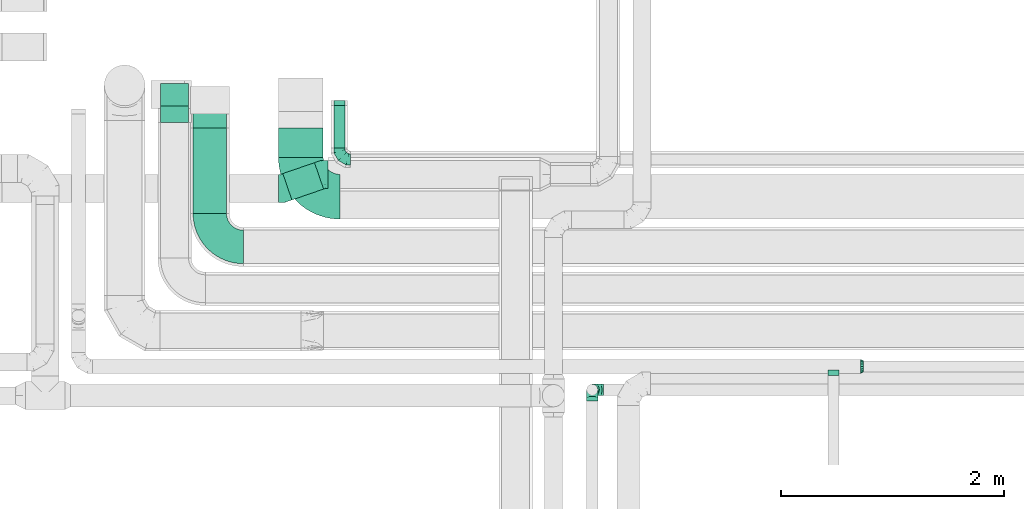
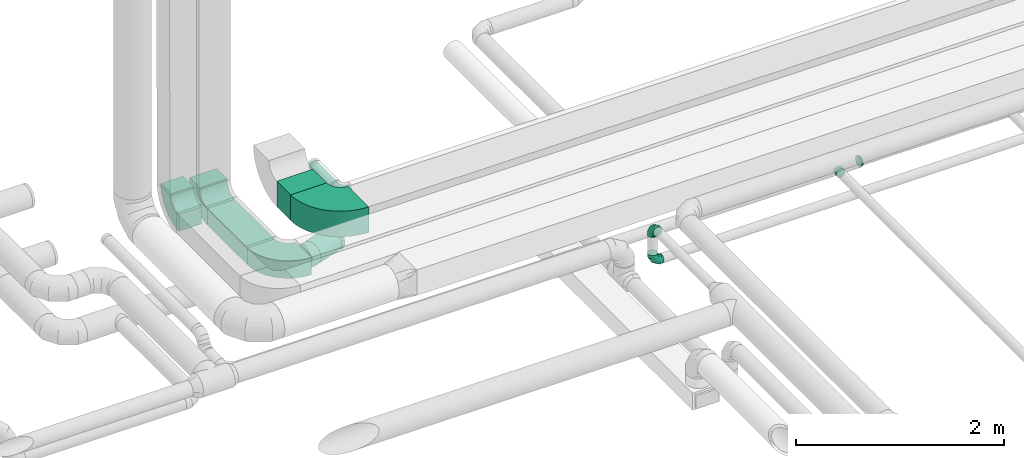
# One storey, part 39 of 92: 12 flow fittings, 4 flow segments.
"""IFC2X3 building model written with IfcOpenShell, lengths in millimetres."""

from ifc_helpers import new_model, entity, si_unit, converted_unit, derived_unit, direction, frame, frame_2d, origin, origin_2d_with_axis, place, context, subcontext, project, spatial, polyline, circle_curve, parameter, trimmed, segment, composite_curve, rectangle, circle, outline, extrude, faceted_brep, source, transform, mapped, material, type_object, type_shapes, element, save


model = new_model("IFC2X3")

# Units and contexts
model_context = context("Model", 3, precision=0.01, world=origin(), true_north=direction((6.12303176911189e-17, 1.0)))
body_context = subcontext(model_context, "Body", "Model", "MODEL_VIEW")
ifc_project = project(units=[si_unit("LENGTHUNIT", "METRE", prefix="MILLI"), si_unit("AREAUNIT", "SQUARE_METRE"), si_unit("VOLUMEUNIT", "CUBIC_METRE"), converted_unit("PLANEANGLEUNIT", "DEGREE", entity("IfcRatioMeasure", 0.0174532925199433), si_unit("PLANEANGLEUNIT", "RADIAN"), dimensions=[0, 0, 0, 0, 0, 0, 0]), si_unit("MASSUNIT", "GRAM", prefix="KILO"), derived_unit("MASSDENSITYUNIT", [(si_unit("MASSUNIT", "GRAM", prefix="KILO"), 1), (si_unit("LENGTHUNIT", "METRE"), -3)]), derived_unit("MOMENTOFINERTIAUNIT", [(si_unit("LENGTHUNIT", "METRE"), 4)]), si_unit("TIMEUNIT", "SECOND"), si_unit("FREQUENCYUNIT", "HERTZ"), si_unit("THERMODYNAMICTEMPERATUREUNIT", "DEGREE_CELSIUS"), derived_unit("THERMALTRANSMITTANCEUNIT", [(si_unit("MASSUNIT", "GRAM", prefix="KILO"), 1), (si_unit("THERMODYNAMICTEMPERATUREUNIT", "KELVIN"), -1), (si_unit("TIMEUNIT", "SECOND"), -3)]), derived_unit("VOLUMETRICFLOWRATEUNIT", [(si_unit("LENGTHUNIT", "METRE"), 3), (si_unit("TIMEUNIT", "SECOND"), -1)]), derived_unit("MASSFLOWRATEUNIT", [(si_unit("MASSUNIT", "GRAM", prefix="KILO"), 1), (si_unit("TIMEUNIT", "SECOND"), -1)]), derived_unit("ROTATIONALFREQUENCYUNIT", [(si_unit("TIMEUNIT", "SECOND"), -1)]), si_unit("ELECTRICCURRENTUNIT", "AMPERE"), si_unit("ELECTRICVOLTAGEUNIT", "VOLT"), si_unit("POWERUNIT", "WATT"), si_unit("FORCEUNIT", "NEWTON", prefix="KILO"), si_unit("ILLUMINANCEUNIT", "LUX"), si_unit("LUMINOUSFLUXUNIT", "LUMEN"), si_unit("LUMINOUSINTENSITYUNIT", "CANDELA"), derived_unit("USERDEFINED", [(si_unit("MASSUNIT", "GRAM", prefix="KILO"), -1), (si_unit("LENGTHUNIT", "METRE"), -2), (si_unit("TIMEUNIT", "SECOND"), 3), (si_unit("LUMINOUSFLUXUNIT", "LUMEN"), 1)]), derived_unit("LINEARVELOCITYUNIT", [(si_unit("LENGTHUNIT", "METRE"), 1), (si_unit("TIMEUNIT", "SECOND"), -1)]), si_unit("PRESSUREUNIT", "PASCAL"), derived_unit("USERDEFINED", [(si_unit("LENGTHUNIT", "METRE"), -2), (si_unit("MASSUNIT", "GRAM", prefix="KILO"), 1), (si_unit("TIMEUNIT", "SECOND"), -2)]), derived_unit("LINEARFORCEUNIT", [(si_unit("MASSUNIT", "GRAM", prefix="KILO"), 1), (si_unit("LENGTHUNIT", "METRE"), 1), (si_unit("TIMEUNIT", "SECOND"), -2), (si_unit("LENGTHUNIT", "METRE"), -1)]), derived_unit("PLANARFORCEUNIT", [(si_unit("MASSUNIT", "GRAM", prefix="KILO"), 1), (si_unit("LENGTHUNIT", "METRE"), 1), (si_unit("TIMEUNIT", "SECOND"), -2), (si_unit("LENGTHUNIT", "METRE"), -2)])], contexts=[model_context])

# Site, building, storey
site_placement = place(None, origin())
site = spatial("IfcSite", under=ifc_project, at=site_placement, CompositionType="ELEMENT")
building_placement = place(site_placement, origin())
building = spatial("IfcBuilding", under=site, at=building_placement, CompositionType="ELEMENT")
storey_placement = place(building_placement, frame((0.0, 0.0, 4200.0)))
storey = spatial("IfcBuildingStorey", under=building, at=storey_placement, CompositionType="ELEMENT", Elevation=4200.0)

# Flow segments
duct_segment_type_1 = type_object("IfcDuctSegmentType", PredefinedType="NOTDEFINED")
flow_segment_1_placement = place(storey_placement, frame((9980.0, 13369.63, 3150.0)))
element("IfcFlowSegment", 1, at=flow_segment_1_placement, inside=storey, type_object=duct_segment_type_1, context=body_context, shape_type="SweptSolid", body=[
    extrude(rectangle(XDim=264.384478781449, YDim=400.0, at=origin_2d_with_axis()), frame((200.0, 132.19, 0.0), z_axis=(0.0, 0.0, 1.0), x_axis=(0.0, -1.0, 0.0)), (0.0, 0.0, 1.0), 300.000000000001),
])
flow_segment_2_placement = place(storey_placement, frame((9214.47, 12869.66, 3200.0)))
element("IfcFlowSegment", 2, at=flow_segment_2_placement, inside=storey, type_object=duct_segment_type_1, context=body_context, shape_type="SweptSolid", body=[
    extrude(rectangle(XDim=764.374757491824, YDim=300.0, at=origin_2d_with_axis()), frame((150.0, 382.19, 0.0), z_axis=(0.0, 0.0, 1.0), x_axis=(0.0, 1.0, 0.0)), (0.0, 0.0, 1.0), 200.0),
])
duct_segment_type_2 = type_object("IfcDuctSegmentType", PredefinedType="NOTDEFINED")
flow_segment_3_placement = place(storey_placement, frame((10473.31, 13454.28, 3248.4)))
element("IfcFlowSegment", 3, at=flow_segment_3_placement, inside=storey, type_object=duct_segment_type_2, context=body_context, shape_type="SweptSolid", body=[
    extrude(circle(Radius=50.0, at=origin_2d_with_axis()), frame((51.6, 0.0, 51.6), z_axis=(0.0, 1.0, 0.0), x_axis=(1.0, 0.0, 0.0)), (0.0, 0.0, 1.0), 382.222629872905),
])
flow_segment_4_placement = place(storey_placement, frame((10016.94, 12988.87, 2773.4)))
element("IfcFlowSegment", 4, at=flow_segment_4_placement, inside=storey, type_object=duct_segment_type_2, context=body_context, shape_type="SweptSolid", body=[
    extrude(circle(Radius=125.0, at=origin_2d_with_axis()), frame((42.29, 119.79, 126.6), z_axis=(0.945518575599296, 0.325568154457217, 0.0), x_axis=(-0.325568154457217, 0.945518575599296, 0.0)), (0.0, 0.0, 1.0), 300.171197948782),
])

# Flow fittings
ifc_material = material()
duct_fitting_type_1 = type_object("IfcDuctFittingType", PredefinedType="NOTDEFINED", material=ifc_material)
shared_shape_1 = source(origin(), body_context, "Body", "Brep", [
    faceted_brep([(-100.0, 0.0, -50.0), (-100.0, -12.94, -48.3), (-100.0, -25.0, -43.3), (-100.0, -35.36, -35.36), (-100.0, -43.3, -25.0), (-100.0, -48.3, -12.94), (-100.0, -50.0, 0.0), (-100.0, -48.3, 12.94), (-100.0, -43.3, 25.0), (-100.0, -35.36, 35.36), (-100.0, -25.0, 43.3), (-100.0, -12.94, 48.3), (-100.0, 0.0, 50.0), (-100.0, 12.94, 48.3), (-100.0, 25.0, 43.3), (-100.0, 35.36, 35.36), (-100.0, 43.3, 25.0), (-100.0, 48.3, 12.94), (-100.0, 50.0, 0.0), (-100.0, 48.3, -12.94), (-100.0, 43.3, -25.0), (-100.0, 35.36, -35.36), (-100.0, 25.0, -43.3), (-100.0, 12.94, -48.3), (-76.67, 12.94, 48.3), (-79.9, 25.0, 43.3), (-73.21, 0.0, 50.0), (-82.68, 35.36, 35.36), (-86.15, 48.3, 12.94), (-86.6, 50.0, 0.0), (-84.81, 43.3, 25.0), (-84.81, 43.3, -25.0), (-82.68, 35.36, -35.36), (-86.15, 48.3, -12.94), (-76.67, 12.94, -48.3), (-73.21, 0.0, -50.0), (-79.9, 25.0, -43.3), (-69.74, -12.94, -48.3), (-66.51, -25.0, -43.3), (-63.73, -35.36, -35.36), (-61.6, -43.3, -25.0), (-60.26, -48.3, -12.94), (-59.81, -50.0, 0.0), (-60.26, -48.3, 12.94), (-61.6, -43.3, 25.0), (-63.73, -35.36, 35.36), (-66.51, -25.0, 43.3), (-69.74, -12.94, 48.3), (-36.27, 36.27, 48.3), (-45.1, 45.1, 43.3), (-26.79, 26.79, 50.0), (-52.68, 52.68, 35.36), (-58.49, 58.49, 25.0), (-62.15, 62.15, 12.94), (-63.4, 63.4, 0.0), (-62.15, 62.15, -12.94), (-58.49, 58.49, -25.0), (-52.68, 52.68, -35.36), (-36.27, 36.27, -48.3), (-26.79, 26.79, -50.0), (-45.1, 45.1, -43.3), (-17.32, 17.32, -48.3), (-8.49, 8.49, -43.3), (-0.91, 0.91, -35.36), (4.9, -4.9, -25.0), (8.56, -8.56, -12.94), (9.81, -9.81, 0.0), (8.56, -8.56, 12.94), (4.9, -4.9, 25.0), (-0.91, 0.91, 35.36), (-8.49, 8.49, 43.3), (-17.32, 17.32, 48.3), (-12.94, 76.67, 48.3), (-25.0, 79.9, 43.3), (0.0, 73.21, 50.0), (-35.36, 82.68, 35.36), (-43.3, 84.81, 25.0), (-48.3, 86.15, 12.94), (-50.0, 86.6, 0.0), (-48.3, 86.15, -12.94), (-43.3, 84.81, -25.0), (-35.36, 82.68, -35.36), (-12.94, 76.67, -48.3), (0.0, 73.21, -50.0), (-25.0, 79.9, -43.3), (12.94, 69.74, -48.3), (25.0, 66.51, -43.3), (35.36, 63.73, -35.36), (43.3, 61.6, -25.0), (48.3, 60.26, -12.94), (50.0, 59.81, 0.0), (48.3, 60.26, 12.94), (43.3, 61.6, 25.0), (35.36, 63.73, 35.36), (25.0, 66.51, 43.3), (12.94, 69.74, 48.3), (-12.94, 100.0, -48.3), (-25.0, 100.0, -43.3), (-35.36, 100.0, -35.36), (-43.3, 100.0, -25.0), (-48.3, 100.0, -12.94), (-50.0, 100.0, 0.0), (-48.3, 100.0, 12.94), (-43.3, 100.0, 25.0), (-35.36, 100.0, 35.36), (-25.0, 100.0, 43.3), (-12.94, 100.0, 48.3), (0.0, 100.0, 50.0), (12.94, 100.0, 48.3), (25.0, 100.0, 43.3), (35.36, 100.0, 35.36), (43.3, 100.0, 25.0), (48.3, 100.0, 12.94), (50.0, 100.0, 0.0), (48.3, 100.0, -12.94), (43.3, 100.0, -25.0), (35.36, 100.0, -35.36), (25.0, 100.0, -43.3), (12.94, 100.0, -48.3), (0.0, 100.0, -50.0)], [[[0, 1, 2, 3, 4, 5, 6, 7, 8, 9, 10, 11, 12, 13, 14, 15, 16, 17, 18, 19, 20, 21, 22, 23]], [[24, 25, 14, 13]], [[26, 24, 13, 12]], [[14, 25, 27, 15]], [[28, 29, 18, 17]], [[30, 28, 17, 16]], [[15, 27, 30, 16]], [[20, 31, 32, 21]], [[33, 31, 20, 19]], [[18, 29, 33, 19]], [[34, 35, 0, 23]], [[36, 34, 23, 22]], [[32, 36, 22, 21]], [[2, 1, 37, 38]], [[3, 2, 38, 39]], [[0, 35, 37, 1]], [[5, 4, 40, 41]], [[6, 5, 41, 42]], [[3, 39, 40, 4]], [[6, 42, 43, 7]], [[7, 43, 44, 8]], [[8, 44, 45, 9]], [[10, 46, 47, 11]], [[11, 47, 26, 12]], [[10, 9, 45, 46]], [[48, 49, 25, 24]], [[50, 48, 24, 26]], [[27, 25, 49, 51]], [[52, 53, 28, 30]], [[51, 52, 30, 27]], [[29, 28, 53, 54]], [[55, 56, 31, 33]], [[54, 55, 33, 29]], [[57, 32, 31, 56]], [[58, 59, 35, 34]], [[60, 58, 34, 36]], [[57, 60, 36, 32]], [[37, 35, 59, 61]], [[38, 37, 61, 62]], [[39, 38, 62, 63]], [[41, 40, 64, 65]], [[42, 41, 65, 66]], [[63, 64, 40, 39]], [[43, 42, 66, 67]], [[44, 43, 67, 68]], [[68, 69, 45, 44]], [[46, 45, 69, 70]], [[47, 46, 70, 71]], [[26, 47, 71, 50]], [[72, 73, 49, 48]], [[74, 72, 48, 50]], [[51, 49, 73, 75]], [[76, 77, 53, 52]], [[75, 76, 52, 51]], [[54, 53, 77, 78]], [[79, 80, 56, 55]], [[78, 79, 55, 54]], [[81, 57, 56, 80]], [[82, 83, 59, 58]], [[84, 82, 58, 60]], [[81, 84, 60, 57]], [[61, 59, 83, 85]], [[62, 61, 85, 86]], [[63, 62, 86, 87]], [[65, 64, 88, 89]], [[66, 65, 89, 90]], [[87, 88, 64, 63]], [[67, 66, 90, 91]], [[68, 67, 91, 92]], [[92, 93, 69, 68]], [[70, 69, 93, 94]], [[71, 70, 94, 95]], [[50, 71, 95, 74]], [[96, 97, 98, 99, 100, 101, 102, 103, 104, 105, 106, 107, 108, 109, 110, 111, 112, 113, 114, 115, 116, 117, 118, 119]], [[72, 74, 107, 106]], [[73, 72, 106, 105]], [[75, 73, 105, 104]], [[77, 76, 103, 102]], [[78, 77, 102, 101]], [[75, 104, 103, 76]], [[78, 101, 100, 79]], [[79, 100, 99, 80]], [[80, 99, 98, 81]], [[96, 119, 83, 82]], [[97, 96, 82, 84]], [[84, 81, 98, 97]], [[83, 119, 118, 85]], [[85, 118, 117, 86]], [[86, 117, 116, 87]], [[88, 115, 114, 89]], [[89, 114, 113, 90]], [[87, 116, 115, 88]], [[91, 90, 113, 112]], [[92, 91, 112, 111]], [[93, 92, 111, 110]], [[95, 94, 109, 108]], [[74, 95, 108, 107]], [[110, 109, 94, 93]]]),
])
type_shapes(duct_fitting_type_1, [shared_shape_1])
for number, where, z_axis, x_axis in (
    (5, (10524.9, 13354.28, 3300.0), (0.0, 0.0, 1.0), (0.0, -1.0, 0.0)),
    (6, (12790.5, 11289.94, 2950.0), (0.0, 1.0, 0.0), (-1.0, 0.0, 0.0)),
    (7, (12790.5, 11289.94, 3360.0), (1.0, 0.0, 0.0), (0.0, 0.0, 1.0)),
):
    element("IfcFlowFitting", number, at=place(storey_placement, frame(where, z_axis=z_axis, x_axis=x_axis)), inside=storey, type_object=duct_fitting_type_1, material=ifc_material, context=body_context, shape_type="MappedRepresentation", body=[
        mapped(shared_shape_1, transform((0.0, 0.0, 0.0), scale=1.0)),
    ])
duct_fitting_type_2 = type_object("IfcDuctFittingType", PredefinedType="NOTDEFINED", material=ifc_material)
shared_shape_2 = source(origin(), body_context, "Body", "Brep", [
    faceted_brep([(20.0, 12.94, -48.3), (20.0, 25.0, -43.3), (20.0, 35.36, -35.36), (20.0, 43.3, -25.0), (20.0, 48.3, -12.94), (20.0, 50.0, 0.0), (20.0, 48.3, 12.94), (20.0, 43.3, 25.0), (20.0, 35.36, 35.36), (20.0, 25.0, 43.3), (20.0, 12.94, 48.3), (20.0, 0.0, 50.0), (20.0, -12.94, 48.3), (20.0, -25.0, 43.3), (20.0, -35.36, 35.36), (20.0, -43.3, 25.0), (20.0, -48.3, 12.94), (20.0, -50.0, 0.0), (20.0, -48.3, -12.94), (20.0, -43.3, -25.0), (20.0, -35.36, -35.36), (20.0, -25.0, -43.3), (20.0, -12.94, -48.3), (20.0, 0.0, -50.0), (0.0, 0.0, 50.0), (0.0, 12.94, 48.3), (-23.65, 12.94, 48.3), (-23.65, 0.0, 50.0), (0.0, 25.0, 43.3), (-23.65, 25.0, 43.3), (0.0, 35.36, 35.36), (-23.65, 35.36, 35.36), (0.0, 43.3, 25.0), (0.0, 48.3, 12.94), (-23.65, 48.3, 12.94), (-23.65, 43.3, 25.0), (0.0, 50.0, 0.0), (-23.65, 50.0, 0.0), (0.0, 48.3, -12.94), (-23.65, 48.3, -12.94), (0.0, 43.3, -25.0), (-23.65, 43.3, -25.0), (0.0, 35.36, -35.36), (-23.65, 35.36, -35.36), (0.0, 25.0, -43.3), (0.0, 12.94, -48.3), (-23.65, 12.94, -48.3), (-23.65, 25.0, -43.3), (0.0, 0.0, -50.0), (-23.65, 0.0, -50.0), (0.0, -12.94, -48.3), (-23.65, -12.94, -48.3), (0.0, -25.0, -43.3), (-23.65, -25.0, -43.3), (0.0, -35.36, -35.36), (-23.65, -35.36, -35.36), (0.0, -43.3, -25.0), (0.0, -48.3, -12.94), (-23.65, -48.3, -12.94), (-23.65, -43.3, -25.0), (0.0, -50.0, 0.0), (-23.65, -50.0, 0.0), (0.0, -48.3, 12.94), (-23.65, -48.3, 12.94), (0.0, -43.3, 25.0), (-23.65, -43.3, 25.0), (0.0, -35.36, 35.36), (-23.65, -35.36, 35.36), (0.0, -25.0, 43.3), (0.0, -12.94, 48.3), (-23.65, -12.94, 48.3), (-23.65, -25.0, 43.3)], [[[0, 1, 2, 3, 4, 5, 6, 7, 8, 9, 10, 11, 12, 13, 14, 15, 16, 17, 18, 19, 20, 21, 22, 23]], [[24, 11, 10, 25, 26, 27]], [[25, 10, 9, 28, 29, 26]], [[28, 9, 8, 30, 31, 29]], [[32, 7, 6, 33, 34, 35]], [[33, 6, 5, 36, 37, 34]], [[30, 8, 7, 32, 35, 31]], [[36, 5, 4, 38, 39, 37]], [[38, 4, 3, 40, 41, 39]], [[40, 3, 2, 42, 43, 41]], [[44, 1, 0, 45, 46, 47]], [[45, 0, 23, 48, 49, 46]], [[42, 2, 1, 44, 47, 43]], [[48, 23, 22, 50, 51, 49]], [[50, 22, 21, 52, 53, 51]], [[52, 21, 20, 54, 55, 53]], [[56, 19, 18, 57, 58, 59]], [[57, 18, 17, 60, 61, 58]], [[54, 20, 19, 56, 59, 55]], [[60, 17, 16, 62, 63, 61]], [[62, 16, 15, 64, 65, 63]], [[64, 15, 14, 66, 67, 65]], [[68, 13, 12, 69, 70, 71]], [[69, 12, 11, 24, 27, 70]], [[66, 14, 13, 68, 71, 67]], [[49, 51, 53, 55, 59, 58, 61, 63, 65, 67, 71, 70, 27, 26, 29, 31, 35, 34, 37, 39, 41, 43, 47, 46]]]),
])
type_shapes(duct_fitting_type_2, [shared_shape_2])
flow_fitting_1_placement = place(storey_placement, frame((10524.9, 13856.5, 3300.0), z_axis=(-1.0, 0.0, 0.0), x_axis=(0.0, -1.0, 0.0)))
element("IfcFlowFitting", 8, at=flow_fitting_1_placement, inside=storey, type_object=duct_fitting_type_2, material=ifc_material, context=body_context, shape_type="MappedRepresentation", body=[
    mapped(shared_shape_2, transform((0.0, 0.0, 0.0), scale=1.0)),
])
duct_fitting_type_3 = type_object("IfcDuctFittingType", PredefinedType="NOTDEFINED", material=ifc_material)
shared_shape_3 = source(origin(), body_context, "Body", "Brep", [
    faceted_brep([(20.0, 12.94, -48.3), (20.0, 25.0, -43.3), (20.0, 35.36, -35.36), (20.0, 43.3, -25.0), (20.0, 48.3, -12.94), (20.0, 50.0, 0.0), (20.0, 48.3, 12.94), (20.0, 43.3, 25.0), (20.0, 35.36, 35.36), (20.0, 25.0, 43.3), (20.0, 12.94, 48.3), (20.0, 0.0, 50.0), (20.0, -12.94, 48.3), (20.0, -25.0, 43.3), (20.0, -35.36, 35.36), (20.0, -43.3, 25.0), (20.0, -48.3, 12.94), (20.0, -50.0, 0.0), (20.0, -48.3, -12.94), (20.0, -43.3, -25.0), (20.0, -35.36, -35.36), (20.0, -25.0, -43.3), (20.0, -12.94, -48.3), (20.0, 0.0, -50.0), (0.0, 0.0, 50.0), (0.0, 12.94, 48.3), (-31.1, 12.94, 48.3), (-31.1, 0.0, 50.0), (0.0, 25.0, 43.3), (-31.1, 25.0, 43.3), (0.0, 35.36, 35.36), (-31.1, 35.36, 35.36), (0.0, 43.3, 25.0), (0.0, 48.3, 12.94), (-31.1, 48.3, 12.94), (-31.1, 43.3, 25.0), (0.0, 50.0, 0.0), (-31.1, 50.0, 0.0), (0.0, 48.3, -12.94), (-31.1, 48.3, -12.94), (0.0, 43.3, -25.0), (-31.1, 43.3, -25.0), (0.0, 35.36, -35.36), (-31.1, 35.36, -35.36), (0.0, 25.0, -43.3), (0.0, 12.94, -48.3), (-31.1, 12.94, -48.3), (-31.1, 25.0, -43.3), (0.0, 0.0, -50.0), (-31.1, 0.0, -50.0), (0.0, -12.94, -48.3), (-31.1, -12.94, -48.3), (0.0, -25.0, -43.3), (-31.1, -25.0, -43.3), (0.0, -35.36, -35.36), (-31.1, -35.36, -35.36), (0.0, -43.3, -25.0), (0.0, -48.3, -12.94), (-31.1, -48.3, -12.94), (-31.1, -43.3, -25.0), (0.0, -50.0, 0.0), (-31.1, -50.0, 0.0), (0.0, -48.3, 12.94), (-31.1, -48.3, 12.94), (0.0, -43.3, 25.0), (-31.1, -43.3, 25.0), (0.0, -35.36, 35.36), (-31.1, -35.36, 35.36), (0.0, -25.0, 43.3), (0.0, -12.94, 48.3), (-31.1, -12.94, 48.3), (-31.1, -25.0, 43.3)], [[[0, 1, 2, 3, 4, 5, 6, 7, 8, 9, 10, 11, 12, 13, 14, 15, 16, 17, 18, 19, 20, 21, 22, 23]], [[24, 11, 10, 25, 26, 27]], [[25, 10, 9, 28, 29, 26]], [[28, 9, 8, 30, 31, 29]], [[32, 7, 6, 33, 34, 35]], [[33, 6, 5, 36, 37, 34]], [[30, 8, 7, 32, 35, 31]], [[36, 5, 4, 38, 39, 37]], [[38, 4, 3, 40, 41, 39]], [[40, 3, 2, 42, 43, 41]], [[44, 1, 0, 45, 46, 47]], [[45, 0, 23, 48, 49, 46]], [[42, 2, 1, 44, 47, 43]], [[48, 23, 22, 50, 51, 49]], [[50, 22, 21, 52, 53, 51]], [[52, 21, 20, 54, 55, 53]], [[56, 19, 18, 57, 58, 59]], [[57, 18, 17, 60, 61, 58]], [[54, 20, 19, 56, 59, 55]], [[60, 17, 16, 62, 63, 61]], [[62, 16, 15, 64, 65, 63]], [[64, 15, 14, 66, 67, 65]], [[68, 13, 12, 69, 70, 71]], [[69, 12, 11, 24, 27, 70]], [[66, 14, 13, 68, 71, 67]], [[49, 51, 53, 55, 59, 58, 61, 63, 65, 67, 71, 70, 27, 26, 29, 31, 35, 34, 37, 39, 41, 43, 47, 46]]]),
])
type_shapes(duct_fitting_type_3, [shared_shape_3])
flow_fitting_2_placement = place(storey_placement, frame((14950.42, 11437.18, 3150.0), z_axis=(0.0, 0.0, -1.0), x_axis=(0.0, -1.0, 0.0)))
element("IfcFlowFitting", 9, at=flow_fitting_2_placement, inside=storey, type_object=duct_fitting_type_3, material=ifc_material, context=body_context, shape_type="MappedRepresentation", body=[
    mapped(shared_shape_3, transform((0.0, 0.0, 0.0), scale=1.0)),
])
duct_fitting_type_4 = type_object("IfcDuctFittingType", PredefinedType="NOTDEFINED", material=ifc_material)
shared_shape_4 = source(origin(), body_context, "Body", "Brep", [
    faceted_brep([(25.0, 0.0, -62.5), (25.0, 12.45, -60.02), (25.0, 23.92, -57.74), (25.0, 34.06, -50.97), (25.0, 44.19, -44.19), (25.0, 50.97, -34.06), (25.0, 57.74, -23.92), (25.0, 60.02, -12.45), (25.0, 62.5, 0.0), (25.0, 60.02, 12.45), (25.0, 57.74, 23.92), (25.0, 50.97, 34.06), (25.0, 44.19, 44.19), (25.0, 34.06, 50.97), (25.0, 23.92, 57.74), (25.0, 12.45, 60.02), (25.0, 0.0, 62.5), (25.0, -12.45, 60.02), (25.0, -23.92, 57.74), (25.0, -34.06, 50.97), (25.0, -44.19, 44.19), (25.0, -50.97, 34.06), (25.0, -57.74, 23.92), (25.0, -60.02, 12.45), (25.0, -62.5, 0.0), (25.0, -60.02, -12.45), (25.0, -57.74, -23.92), (25.0, -50.97, -34.06), (25.0, -44.19, -44.19), (25.0, -34.06, -50.97), (25.0, -23.92, -57.74), (25.0, -12.45, -60.02), (0.0, -19.13, -46.19), (0.0, -27.24, -40.77), (0.0, -35.36, -35.36), (0.0, -40.77, -27.24), (0.0, -46.19, -19.13), (0.0, -48.1, -9.57), (0.0, -50.0, 0.0), (0.0, -48.1, 9.57), (0.0, -46.19, 19.13), (0.0, -40.77, 27.24), (0.0, -35.36, 35.36), (0.0, -27.24, 40.77), (0.0, -19.13, 46.19), (0.0, -9.57, 48.1), (0.0, 0.0, 50.0), (0.0, 9.57, 48.1), (0.0, 19.13, 46.19), (0.0, 27.24, 40.77), (0.0, 35.36, 35.36), (0.0, 40.77, 27.24), (0.0, 46.19, 19.13), (0.0, 48.1, 9.57), (0.0, 50.0, 0.0), (0.0, 48.1, -9.57), (0.0, 46.19, -19.13), (0.0, 40.77, -27.24), (0.0, 35.36, -35.36), (0.0, 27.24, -40.77), (0.0, 19.13, -46.19), (0.0, 9.57, -48.1), (0.0, 0.0, -50.0), (0.0, -9.57, -48.1)], [[[0, 1, 2, 3, 4, 5, 6, 7, 8, 9, 10, 11, 12, 13, 14, 15, 16, 17, 18, 19, 20, 21, 22, 23, 24, 25, 26, 27, 28, 29, 30, 31]], [[32, 33, 34, 35, 36, 37, 38, 39, 40, 41, 42, 43, 44, 45, 46, 47, 48, 49, 50, 51, 52, 53, 54, 55, 56, 57, 58, 59, 60, 61, 62, 63]], [[52, 10, 9, 8, 54, 53]], [[51, 50, 12, 11, 10, 52]], [[47, 46, 16, 15, 14, 48]], [[49, 48, 14, 13, 12, 50]], [[44, 18, 17, 16, 46, 45]], [[43, 42, 20, 19, 18, 44]], [[39, 38, 24, 23, 22, 40]], [[41, 40, 22, 21, 20, 42]], [[36, 26, 25, 24, 38, 37]], [[35, 34, 28, 27, 26, 36]], [[63, 62, 0, 31, 30, 32]], [[33, 32, 30, 29, 28, 34]], [[60, 2, 1, 0, 62, 61]], [[59, 58, 4, 3, 2, 60]], [[55, 54, 8, 7, 6, 56]], [[57, 56, 6, 5, 4, 58]]]),
])
type_shapes(duct_fitting_type_4, [shared_shape_4])
flow_fitting_3_placement = place(storey_placement, frame((15219.69, 11499.68, 3150.0), z_axis=(0.0, 0.0, 1.0), x_axis=(-1.0, 0.0, 0.0)))
element("IfcFlowFitting", 10, at=flow_fitting_3_placement, inside=storey, type_object=duct_fitting_type_4, material=ifc_material, context=body_context, shape_type="MappedRepresentation", body=[
    mapped(shared_shape_4, transform((0.0, 0.0, 0.0), scale=1.0)),
])
duct_fitting_type_5 = type_object("IfcDuctFittingType", PredefinedType="NOTDEFINED", material=ifc_material)
shared_shape_5 = source(origin(), body_context, "Body", "Brep", [
    faceted_brep([(-41.84, 0.0, -125.0), (-41.84, -32.35, -120.74), (-41.84, -62.5, -108.25), (-41.84, -88.39, -88.39), (-41.84, -108.25, -62.5), (-41.84, -120.74, -32.35), (-41.84, -125.0, 0.0), (-41.84, -120.74, 32.35), (-41.84, -108.25, 62.5), (-41.84, -88.39, 88.39), (-41.84, -62.5, 108.25), (-41.84, -32.35, 120.74), (-41.84, 0.0, 125.0), (-41.84, 32.35, 120.74), (-41.84, 62.5, 108.25), (-41.84, 88.39, 88.39), (-41.84, 108.25, 62.5), (-41.84, 120.74, 32.35), (-41.84, 125.0, 0.0), (-41.84, 120.74, -32.35), (-41.84, 108.25, -62.5), (-41.84, 88.39, -88.39), (-41.84, 62.5, -108.25), (-41.84, 32.35, -120.74), (-5.41, 32.35, 120.74), (-10.46, 62.5, 108.25), (0.0, 0.0, 125.0), (-14.79, 88.39, 88.39), (-20.21, 120.74, 32.35), (-20.92, 125.0, 0.0), (-18.12, 108.25, 62.5), (-18.12, 108.25, -62.5), (-14.79, 88.39, -88.39), (-20.21, 120.74, -32.35), (-5.41, 32.35, -120.74), (0.0, 0.0, -125.0), (-10.46, 62.5, -108.25), (5.41, -32.35, -120.74), (10.46, -62.5, -108.25), (14.79, -88.39, -88.39), (18.12, -108.25, -62.5), (20.21, -120.74, -32.35), (20.92, -125.0, 0.0), (20.21, -120.74, 32.35), (18.12, -108.25, 62.5), (14.79, -88.39, 88.39), (10.46, -62.5, 108.25), (5.41, -32.35, 120.74), (39.56, 13.62, 125.0), (29.02, 44.21, 120.74), (19.21, 72.72, 108.25), (10.78, 97.19, 88.39), (4.31, 115.98, 62.5), (0.25, 127.78, 32.35), (-1.14, 131.81, 0.0), (0.25, 127.78, -32.35), (4.31, 115.98, -62.5), (10.78, 97.19, -88.39), (19.21, 72.72, -108.25), (29.02, 44.21, -120.74), (39.56, 13.62, -125.0), (50.09, -16.97, -120.74), (59.9, -45.47, -108.25), (68.33, -69.95, -88.39), (74.8, -88.74, -62.5), (78.87, -100.54, -32.35), (80.25, -104.57, 0.0), (78.87, -100.54, 32.35), (74.8, -88.74, 62.5), (68.33, -69.95, 88.39), (50.09, -16.97, 120.74), (59.9, -45.47, 108.25)], [[[0, 1, 2, 3, 4, 5, 6, 7, 8, 9, 10, 11, 12, 13, 14, 15, 16, 17, 18, 19, 20, 21, 22, 23]], [[24, 25, 14, 13]], [[26, 24, 13, 12]], [[14, 25, 27, 15]], [[28, 29, 18, 17]], [[30, 28, 17, 16]], [[15, 27, 30, 16]], [[20, 31, 32, 21]], [[33, 31, 20, 19]], [[18, 29, 33, 19]], [[34, 35, 0, 23]], [[36, 34, 23, 22]], [[32, 36, 22, 21]], [[2, 1, 37, 38]], [[3, 2, 38, 39]], [[0, 35, 37, 1]], [[5, 4, 40, 41]], [[6, 5, 41, 42]], [[3, 39, 40, 4]], [[6, 42, 43, 7]], [[7, 43, 44, 8]], [[8, 44, 45, 9]], [[10, 46, 47, 11]], [[11, 47, 26, 12]], [[10, 9, 45, 46]], [[24, 26, 48, 49]], [[25, 24, 49, 50]], [[27, 25, 50, 51]], [[28, 30, 52, 53]], [[29, 28, 53, 54]], [[27, 51, 52, 30]], [[29, 54, 55, 33]], [[33, 55, 56, 31]], [[31, 56, 57, 32]], [[36, 58, 59, 34]], [[34, 59, 60, 35]], [[36, 32, 57, 58]], [[35, 60, 61, 37]], [[37, 61, 62, 38]], [[38, 62, 63, 39]], [[40, 64, 65, 41]], [[41, 65, 66, 42]], [[39, 63, 64, 40]], [[43, 42, 66, 67]], [[44, 43, 67, 68]], [[45, 44, 68, 69]], [[70, 48, 26, 47]], [[71, 70, 47, 46]], [[69, 71, 46, 45]], [[59, 58, 57, 56, 55, 54, 53, 52, 51, 50, 49, 48, 70, 71, 69, 68, 67, 66, 65, 64, 63, 62, 61, 60]]]),
])
type_shapes(duct_fitting_type_5, [shared_shape_5])
flow_fitting_4_placement = place(storey_placement, frame((10382.61, 13220.0, 2900.0), z_axis=(0.0, 0.0, 1.0), x_axis=(-1.0, 0.0, 0.0)))
element("IfcFlowFitting", 11, at=flow_fitting_4_placement, inside=storey, type_object=duct_fitting_type_5, material=ifc_material, context=body_context, shape_type="MappedRepresentation", body=[
    mapped(shared_shape_5, transform((0.0, 0.0, 0.0), scale=1.0)),
])
flow_fitting_5_placement = place(storey_placement, frame((10019.68, 13095.03, 2900.0)))
element("IfcFlowFitting", 12, at=flow_fitting_5_placement, inside=storey, type_object=duct_fitting_type_5, material=ifc_material, context=body_context, shape_type="MappedRepresentation", body=[
    mapped(shared_shape_5, transform((0.0, 0.0, 0.0), scale=1.0)),
])
duct_fitting_type_6 = type_object("IfcDuctFittingType", PredefinedType="NOTDEFINED", material=ifc_material)
shared_shape_6 = source(origin(), body_context, "Body", "SweptSolid", [
    extrude(outline(composite_curve([segment(polyline([(-225.0, -125.0), (-25.0, -125.0)]), True, "CONTINUOUS"), segment(trimmed(circle_curve(frame_2d((125.0, -125.0), x_axis=(0.0, 1.0)), 150.0), [parameter(0.0)], [parameter(90.0)], True, "PARAMETER"), False, "CONTINUOUS"), segment(polyline([(125.0, 25.0), (125.0, 225.0)]), True, "CONTINUOUS"), segment(trimmed(circle_curve(frame_2d((125.0, -125.0), x_axis=(0.0, 1.0)), 350.0), [parameter(0.0)], [parameter(90.0)], True, "PARAMETER"), True, "CONTINUOUS")], self_intersect=False)), frame((-125.0, 125.0, -125.0), z_axis=(0.0, 0.0, 1.0), x_axis=(-1.0, 0.0, 0.0)), (0.0, 0.0, 1.0), 250.0),
])
type_shapes(duct_fitting_type_6, [shared_shape_6])
flow_fitting_6_placement = place(storey_placement, frame((9049.12, 13933.89, 3300.0), z_axis=(0.999996527502329, 0.0, 0.00263533361906678), x_axis=(0.0, 1.0, 0.0)))
element("IfcFlowFitting", 13, at=flow_fitting_6_placement, inside=storey, type_object=duct_fitting_type_6, material=ifc_material, context=body_context, shape_type="MappedRepresentation", body=[
    mapped(shared_shape_6, transform((0.0, 0.0, 0.0), scale=1.0)),
])
duct_fitting_type_7 = type_object("IfcDuctFittingType", PredefinedType="NOTDEFINED", material=ifc_material)
shared_shape_7 = source(origin(), body_context, "Body", "SweptSolid", [
    extrude(outline(composite_curve([segment(polyline([(-300.0, -150.0), (0.0, -150.0)]), True, "CONTINUOUS"), segment(trimmed(circle_curve(frame_2d((150.0, -150.0), x_axis=(0.0, 1.0)), 150.0), [parameter(0.0)], [parameter(90.0)], True, "PARAMETER"), False, "CONTINUOUS"), segment(polyline([(150.0, 0.0), (150.0, 300.0)]), True, "CONTINUOUS"), segment(trimmed(circle_curve(frame_2d((150.0, -150.0), x_axis=(0.0, 1.0)), 450.0), [parameter(0.0)], [parameter(90.0000000000001)], True, "PARAMETER"), True, "CONTINUOUS")], self_intersect=False)), frame((-150.0, 150.0, -100.0), z_axis=(0.0, 0.0, 1.0), x_axis=(-1.0, 0.0, 0.0)), (0.0, 0.0, 1.0), 200.0),
])
type_shapes(duct_fitting_type_7, [shared_shape_7])
flow_fitting_7_placement = place(storey_placement, frame((9364.47, 12569.66, 3300.0), z_axis=(0.0, 0.0, 1.0), x_axis=(0.0, -1.0, 0.0)))
element("IfcFlowFitting", 14, at=flow_fitting_7_placement, inside=storey, type_object=duct_fitting_type_7, material=ifc_material, context=body_context, shape_type="MappedRepresentation", body=[
    mapped(shared_shape_7, transform((0.0, 0.0, 0.0), scale=1.0)),
])
duct_fitting_type_8 = type_object("IfcDuctFittingType", PredefinedType="NOTDEFINED", material=ifc_material)
shared_shape_8 = source(origin(), body_context, "Body", "SweptSolid", [
    extrude(outline(composite_curve([segment(polyline([(-375.0, -175.0), (25.0, -175.0)]), True, "CONTINUOUS"), segment(trimmed(circle_curve(frame_2d((175.0, -175.0), x_axis=(0.0, 1.0)), 150.0), [parameter(0.0)], [parameter(90.0000000000001)], True, "PARAMETER"), False, "CONTINUOUS"), segment(polyline([(175.0, -25.0), (175.0, 375.0)]), True, "CONTINUOUS"), segment(trimmed(circle_curve(frame_2d((175.0, -175.0), x_axis=(0.0, 1.0)), 550.0), [parameter(0.0)], [parameter(90.0)], True, "PARAMETER"), True, "CONTINUOUS")], self_intersect=False)), frame((-175.0, 175.0, -150.0), z_axis=(0.0, 0.0, 1.0), x_axis=(-1.0, 0.0, 0.0)), (0.0, 0.0, 1.0), 300.0),
])
type_shapes(duct_fitting_type_8, [shared_shape_8])
flow_fitting_8_placement = place(storey_placement, frame((10180.0, 13019.63, 3300.0), z_axis=(0.0, 0.0, 1.0), x_axis=(0.0, -1.0, 0.0)))
element("IfcFlowFitting", 15, at=flow_fitting_8_placement, inside=storey, type_object=duct_fitting_type_8, material=ifc_material, context=body_context, shape_type="MappedRepresentation", body=[
    mapped(shared_shape_8, transform((0.0, 0.0, 0.0), scale=1.0)),
])
duct_fitting_type_9 = type_object("IfcDuctFittingType", PredefinedType="NOTDEFINED", material=ifc_material)
shared_shape_9 = source(origin(), body_context, "Body", "SweptSolid", [
    extrude(outline(composite_curve([segment(polyline([(-225.0, -125.0), (-25.0, -125.0)]), True, "CONTINUOUS"), segment(trimmed(circle_curve(frame_2d((125.0, -125.0), x_axis=(0.0, 1.0)), 150.0), [parameter(0.0)], [parameter(90.0)], True, "PARAMETER"), False, "CONTINUOUS"), segment(polyline([(125.0, 25.0), (125.0, 225.0)]), True, "CONTINUOUS"), segment(trimmed(circle_curve(frame_2d((125.0, -125.0), x_axis=(0.0, 1.0)), 350.0), [parameter(0.0)], [parameter(90.0)], True, "PARAMETER"), True, "CONTINUOUS")], self_intersect=False)), frame((-125.0, 125.0, -150.0), z_axis=(0.0, 0.0, 1.0), x_axis=(-1.0, 0.0, 0.0)), (0.0, 0.0, 1.0), 300.0),
])
type_shapes(duct_fitting_type_9, [shared_shape_9])
flow_fitting_9_placement = place(storey_placement, frame((9364.47, 13884.03, 3300.0), z_axis=(1.0, 0.0, 0.0), x_axis=(0.0, 1.0, 0.0)))
element("IfcFlowFitting", 16, at=flow_fitting_9_placement, inside=storey, type_object=duct_fitting_type_9, material=ifc_material, context=body_context, shape_type="MappedRepresentation", body=[
    mapped(shared_shape_9, transform((0.0, 0.0, 0.0), scale=1.0)),
])

save(model, "model.ifc")
